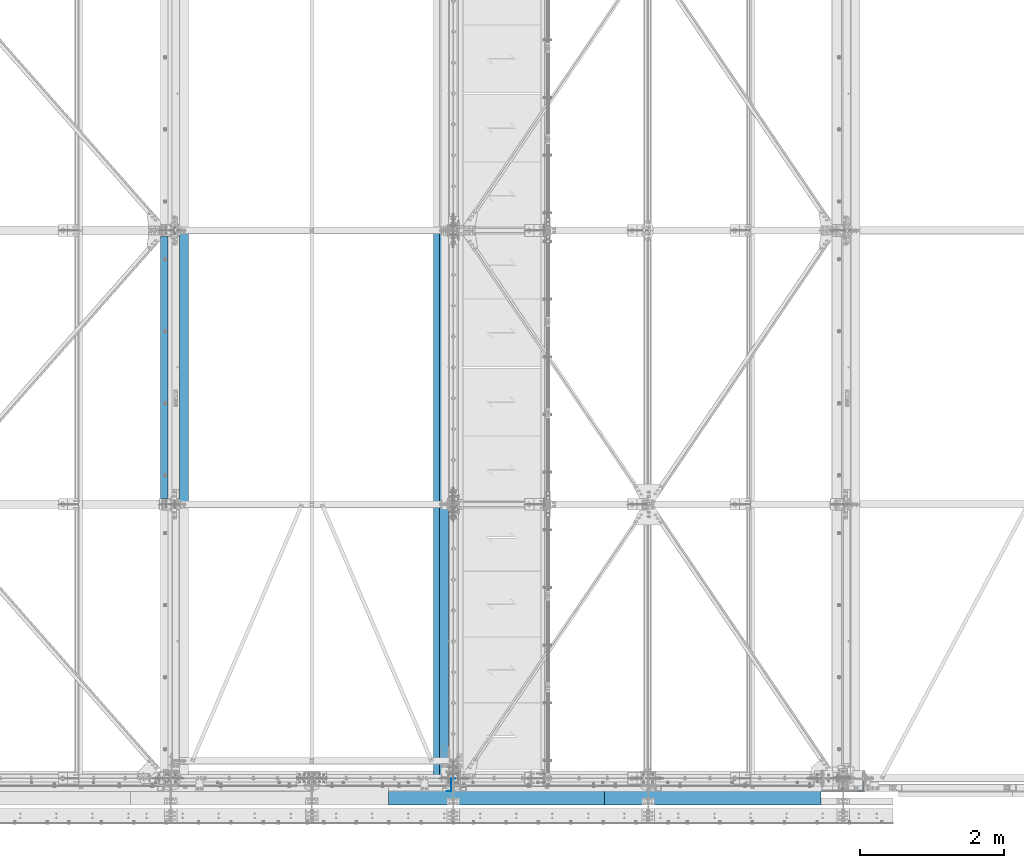
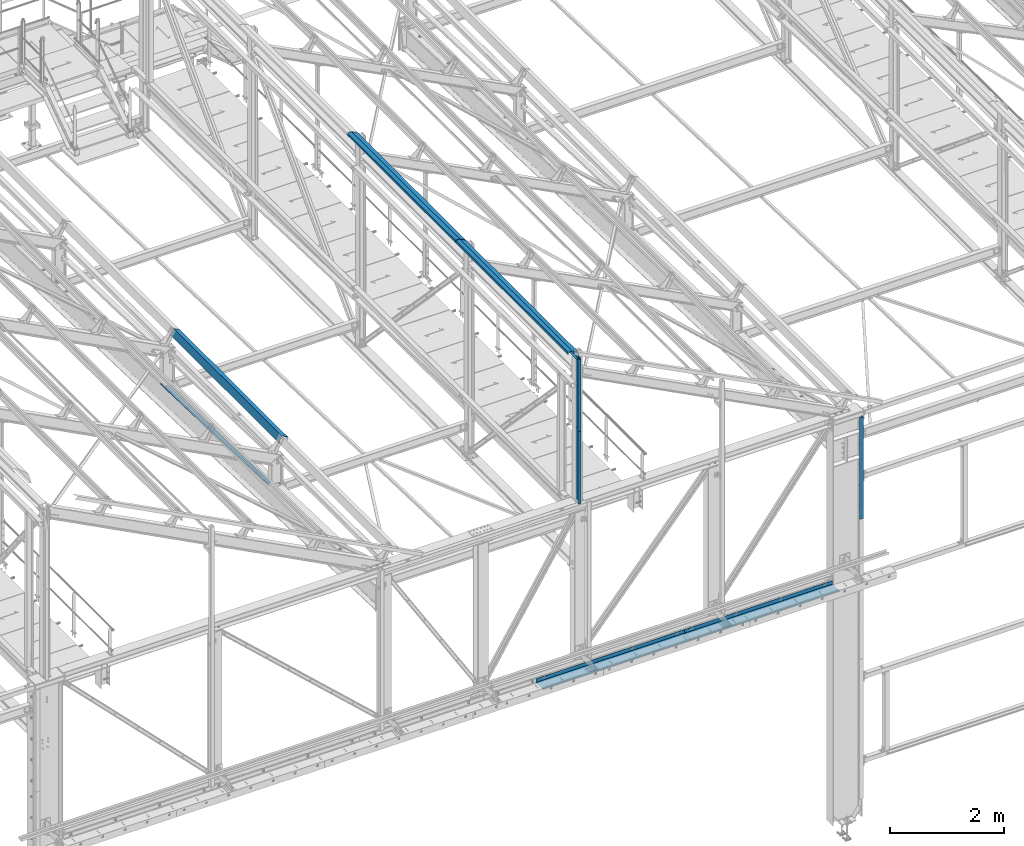
# One storey, part 347 of 496: 9 beams, 9 elements without a shape of their own.
"""IFC2X3 building model written with IfcOpenShell, lengths in millimetres."""

import ifcopenshell
import ifcopenshell.guid

model = None  # the IFC model being written
_history = None  # IfcOwnerHistory: only IFC2X3 demands one
_inside = {}  # id of a spatial element -> (the spatial element, [elements in it])
_under = {}  # id of a project, library or spatial element -> (it, [spatial elements below it])
_declared = {}  # id of a project -> (the project, [libraries it declares])
_typed = {}  # id of a type object -> (the type object, [elements of that type])
_made_of = {}  # id of a material, layer set ... -> (it, [elements and type objects made of it])


def new_model(schema):
    """Start an empty IFC model of exactly this schema.

    Asked for "IFC4X3", IfcOpenShell would pick the latest addendum, in which some entities
    have other attributes; the version numbers below select the first issue.
    IFC2X3 requires an IfcOwnerHistory on every rooted entity: one is made here for all.
    """
    global model, _history
    if schema == "IFC4X3":
        model = ifcopenshell.file(schema_version=(4, 3, 0, 0))
    else:
        model = ifcopenshell.file(schema=schema)
    _inside.clear()
    _under.clear()
    _declared.clear()
    _typed.clear()
    _made_of.clear()
    _history = None
    if model.schema == "IFC2X3":
        org = make("IfcOrganization", Name="unknown")
        user = make(
            "IfcPersonAndOrganization",
            ThePerson=make("IfcPerson", FamilyName="unknown"),
            TheOrganization=org,
        )
        app = make(
            "IfcApplication",
            ApplicationDeveloper=org,
            Version="unknown",
            ApplicationFullName="unknown",
            ApplicationIdentifier="unknown",
        )
        _history = make(
            "IfcOwnerHistory",
            OwningUser=user,
            OwningApplication=app,
            ChangeAction="ADDED",
            CreationDate=0,
        )
    return model


def make(cls, **values):
    """One entity of the class cls with the attributes given. An attribute that is None is left unset."""
    return model.create_entity(
        cls, **{name: value for name, value in values.items() if value is not None}
    )


def rooted(cls, **values):
    """An entity with a GlobalId (a new one), such as an element, a storey or a relation."""
    return make(cls, GlobalId=ifcopenshell.guid.new(), OwnerHistory=_history, **values)


def si_unit(unit_type, name, prefix=None):
    """IfcSIUnit, for example si_unit("LENGTHUNIT", "METRE", prefix="MILLI")."""
    return make("IfcSIUnit", UnitType=unit_type, Prefix=prefix, Name=name)


def assignment(units):
    """IfcUnitAssignment: the units of a project."""
    return None if units is None else make("IfcUnitAssignment", Units=units)


def point(xyz):
    """IfcCartesianPoint."""
    return None if xyz is None else make("IfcCartesianPoint", Coordinates=xyz)


def direction(xyz):
    """IfcDirection."""
    return None if xyz is None else make("IfcDirection", DirectionRatios=xyz)


def frame(location, z_axis=None, x_axis=None):
    """IfcAxis2Placement3D, a coordinate frame: its origin and axes. An axis left out is left unset."""
    return make(
        "IfcAxis2Placement3D",
        Location=point(location),
        Axis=direction(z_axis),
        RefDirection=direction(x_axis),
    )


def origin_with_axes():
    """The frame at (0, 0, 0) with the z axis (0, 0, 1) and the x axis (1, 0, 0) written out."""
    return frame((0.0, 0.0, 0.0), z_axis=(0.0, 0.0, 1.0), x_axis=(1.0, 0.0, 0.0))


def place(relative_to, where):
    """IfcLocalPlacement: puts the frame where relative to a parent placement (None: the world)."""
    return make(
        "IfcLocalPlacement", PlacementRelTo=relative_to, RelativePlacement=where
    )


def context(
    kind, dimensions, precision=None, world=None, true_north=None, identifier=None
):
    """IfcGeometricRepresentationContext, for example the 3D "Model" context."""
    return make(
        "IfcGeometricRepresentationContext",
        ContextIdentifier=identifier,
        ContextType=kind,
        CoordinateSpaceDimension=dimensions,
        Precision=precision,
        WorldCoordinateSystem=world,
        TrueNorth=true_north,
    )


def subcontext(parent, identifier, kind, view, scale=None):
    """IfcGeometricRepresentationSubContext, for example "Body" below "Model"."""
    return make(
        "IfcGeometricRepresentationSubContext",
        ContextIdentifier=identifier,
        ContextType=kind,
        ParentContext=parent,
        TargetScale=scale,
        TargetView=view,
    )


def project(units=None, contexts=None):
    """IfcProject with its units and contexts."""
    return rooted(
        "IfcProject",
        Name="project",
        RepresentationContexts=contexts,
        UnitsInContext=assignment(units),
    )


def spatial(cls, under=None, at=None, **own):
    """A site, building, storey or space (cls), placed at a placement, below another one or the project."""
    s = rooted(cls, ObjectPlacement=at, **own)
    if under is not None:
        _under.setdefault(under.id(), (under, []))[1].append(s)
    return s


def faces_of(points, faces, orient=None, outer=None):
    """IfcFace entities. A face is a list of loops; a loop is a list of indices into points, from 0.

    orient and outer hold one flag for each loop. By default every Orientation is true, the
    first loop of a face is its IfcFaceOuterBound and the others are IfcFaceBound.
    """
    made = []
    for i, loops in enumerate(faces):
        bounds = []
        for j, loop in enumerate(loops):
            is_outer = j == 0 if outer is None else outer[i][j]
            bounds.append(
                make(
                    "IfcFaceOuterBound" if is_outer else "IfcFaceBound",
                    Bound=make("IfcPolyLoop", Polygon=[points[k] for k in loop]),
                    Orientation=True if orient is None else orient[i][j],
                )
            )
        made.append(make("IfcFace", Bounds=bounds))
    return made


def faceted_brep(points, faces, orient=None, outer=None, voids=None):
    """IfcFacetedBrep: a solid bounded by flat faces; with voids (closed shells), ...WithVoids."""
    shared = [point(p) for p in points]
    hull = make("IfcClosedShell", CfsFaces=faces_of(shared, faces, orient, outer))
    if voids is None:
        return make("IfcFacetedBrep", Outer=hull)
    return make(
        "IfcFacetedBrepWithVoids",
        Outer=hull,
        Voids=[
            make(cls, CfsFaces=faces_of(shared, fs, o, b)) for cls, fs, o, b in voids
        ],
    )


def shape(context_of_items, identifier, shape_type, items):
    """IfcShapeRepresentation: the items that make up one representation, for example the "Body"."""
    return make(
        "IfcShapeRepresentation",
        ContextOfItems=context_of_items,
        RepresentationIdentifier=identifier,
        RepresentationType=shape_type,
        Items=items,
    )


def material(Name=None, Category=None):
    """IfcMaterial."""
    return make("IfcMaterial", Name=Name, Category=Category)


def made_of(thing, what):
    """Note that an element or type object is made of a material, layer set ...; save() writes the relation."""
    if what is not None:
        _made_of.setdefault(what.id(), (what, []))[1].append(thing)
    return thing


def type_object(cls, material=None, **own):
    """A type object (cls), such as IfcWallType, which elements share."""
    return made_of(rooted(cls, **own), material)


def element(
    cls,
    number,
    at=None,
    inside=None,
    cuts=None,
    type_object=None,
    material=None,
    context=None,
    identifier="Body",
    shape_type=None,
    held_by="IfcProductDefinitionShape",
    body=None,
    shapes=None,
    **own,
):
    """One element of the class cls, such as IfcWall. Its Tag is "e" and its number.

    at: its placement. inside: the storey or other place that contains it. cuts: it is an
    opening in that element (IfcRelVoidsElement). A single representation is given by context,
    identifier, shape_type and body (its items); several are given by shapes. held_by: the class
    of the entity that holds the representations. save() writes the other relations.
    """
    e = rooted(cls, Tag="e%d" % number, ObjectPlacement=at, **own)
    if body is not None:
        shapes = [shape(context, identifier, shape_type, body)]
    if shapes is not None:
        e.Representation = make(held_by, Representations=shapes)
    if inside is not None:
        _inside.setdefault(inside.id(), (inside, []))[1].append(e)
    if cuts is not None:
        rooted(
            "IfcRelVoidsElement", RelatingBuildingElement=cuts, RelatedOpeningElement=e
        )
    if type_object is not None:
        _typed.setdefault(type_object.id(), (type_object, []))[1].append(e)
    return made_of(e, material)


def aggregate(whole, parts):
    """IfcRelAggregates: a whole, such as a stair, and the parts it consists of."""
    return rooted("IfcRelAggregates", RelatingObject=whole, RelatedObjects=parts)


def save(model, path):
    """Write the relations noted so far, then the file.

    IfcRelAggregates (storeys below a building ...), IfcRelContainedInSpatialStructure (elements
    in a storey), IfcRelDefinesByType, IfcRelAssociatesMaterial and IfcRelDeclares: one each for
    every whole, place, type object, material and project.
    """
    for whole, parts in _under.values():
        aggregate(whole, parts)
    for where, things in _inside.values():
        rooted(
            "IfcRelContainedInSpatialStructure",
            RelatedElements=things,
            RelatingStructure=where,
        )
    for kind, things in _typed.values():
        rooted("IfcRelDefinesByType", RelatedObjects=things, RelatingType=kind)
    for what, things in _made_of.values():
        rooted("IfcRelAssociatesMaterial", RelatedObjects=things, RelatingMaterial=what)
    for by, libraries in _declared.values():
        rooted("IfcRelDeclares", RelatingContext=by, RelatedDefinitions=libraries)
    model.write(path)


model = new_model("IFC2X3")

# Units and contexts
model_context = context("Model", 3, precision=1e-05, world=origin_with_axes())
body_context = subcontext(model_context, "Body", "Model", "MODEL_VIEW")
ifc_project = project(units=[si_unit("LENGTHUNIT", "METRE", prefix="MILLI"), si_unit("AREAUNIT", "SQUARE_METRE"), si_unit("VOLUMEUNIT", "CUBIC_METRE"), si_unit("MASSUNIT", "GRAM", prefix="KILO"), si_unit("TIMEUNIT", "SECOND"), si_unit("PLANEANGLEUNIT", "RADIAN"), si_unit("SOLIDANGLEUNIT", "STERADIAN"), si_unit("THERMODYNAMICTEMPERATUREUNIT", "DEGREE_CELSIUS"), si_unit("LUMINOUSINTENSITYUNIT", "LUMEN")], contexts=[model_context])

# Site, building, storey
site_placement = place(None, origin_with_axes())
site = spatial("IfcSite", under=ifc_project, at=site_placement, CompositionType="ELEMENT")
building_placement = place(site_placement, origin_with_axes())
building = spatial("IfcBuilding", under=site, at=building_placement, Name="Undefined", CompositionType="ELEMENT")
storey_placement = place(building_placement, origin_with_axes())
storey = spatial("IfcBuildingStorey", under=building, at=storey_placement, Name="Undefined", CompositionType="ELEMENT", Elevation=0.0)

# Assembly, beam
assembly_1_placement = place(storey_placement, origin_with_axes())
assembly_1 = element("IfcElementAssembly", 1, at=assembly_1_placement, inside=storey, Name="SHED", AssemblyPlace="NOTDEFINED", PredefinedType="NOTDEFINED")
ifc_material = material(Name="Undefined/S235-E24")
beam_type_1 = type_object("IfcBeamType", PredefinedType="NOTDEFINED")
beam_1_placement = place(assembly_1_placement, frame((19656.0539262703, 5700.00010459345, 8773.41543701898), z_axis=(0.0, 1.0, 0.0), x_axis=(-0.886081824994261, -1.3000000762986e-08, 0.46352885499701)))
beam_1 = element("IfcBeam", 2, at=beam_1_placement, type_object=beam_type_1, material=ifc_material, Name="SHED", context=body_context, shape_type="Brep", body=[
    faceted_brep([(-3.49427864421159e-08, -1.49999999999636, -1895.0), (-3.52956703864038e-08, -1.5, 1895.0), (3.49573383573443e-08, 1.5, 1895.0), (3.53102223016322e-08, 1.5, -1895.0), (47.0000011861484, 1.499998899395, 1895.0), (47.0000011898519, 1.49999889939863, -1895.0), (50.0000011927114, -1.50000117085074, -1895.0), (50.0000011890152, -1.50000117085438, 1895.0), (47.000001059947, 135.500002207569, 1895.00000000012), (47.0000010603762, 135.500002214732, -1894.99999999988), (50.0000010575095, 138.500002217588, -1894.99999999987), (50.0000010570839, 138.500002210421, 1895.00000000013), (-88.1836776470482, 135.500002842484, 1895.0000000002), (-88.1836776506789, 135.500002845067, -1894.9999999998), (-90.0000023299144, 138.50000208251, -1894.99999999975), (-90.0000023251705, 138.500002079061, 1895.00000000025), (-124.424035514965, 66.2228546085316, 1895.00000000021), (-124.424035518201, 66.2228546098777, -1894.99999999979), (-127.082281608209, 67.6134399916555, 1895.00000000021), (-127.082281611441, 67.6134399930015, -1894.99999999979)], [[[0, 1, 2, 3]], [[3, 2, 4, 5]], [[1, 0, 6, 7]], [[5, 4, 8, 9]], [[7, 6, 10, 11]], [[9, 8, 12, 13]], [[11, 10, 14, 15]], [[13, 12, 16, 17]], [[12, 8, 4, 2, 1, 7, 11, 15, 18, 16]], [[15, 14, 19, 18]], [[14, 10, 6, 0, 3, 5, 9, 13, 17, 19]], [[18, 19, 17, 16]]]),
])
aggregate(assembly_1, [beam_1])

assembly_2_placement = place(storey_placement, origin_with_axes())
assembly_2 = element("IfcElementAssembly", 3, at=assembly_2_placement, inside=storey, Name="SHED", AssemblyPlace="NOTDEFINED", PredefinedType="NOTDEFINED")
beam_2_placement = place(assembly_2_placement, frame((23194.99999895, 5700.00015768597, 11825.822934218), z_axis=(0.0, 1.0, 0.0), x_axis=(0.0, 0.0, 1.0)))
beam_2 = element("IfcBeam", 4, at=beam_2_placement, type_object=beam_type_1, material=ifc_material, Name="SHED", context=body_context, shape_type="Brep", body=[
    faceted_brep([(-3.49427864421159e-08, -1.49999999999636, -1895.0), (-3.52956703864038e-08, -1.5, 1895.0), (3.49573383573443e-08, 1.5, 1895.0), (3.53102223016322e-08, 1.5, -1895.0), (47.0000011861484, 1.499998899395, 1895.0), (47.0000011898519, 1.49999889939863, -1895.0), (50.0000011927114, -1.50000117085074, -1895.0), (50.0000011890152, -1.50000117085438, 1895.0), (47.0, 83.4669820349482, 1895.0), (47.0, 83.4669820349482, -1895.0), (50.0, 84.198112487793, -1895.0), (50.0, 84.198112487793, 1895.0), (-16.2373286826551, 205.5, 1895.0), (-16.2373286826551, 205.5, -1895.0), (-14.4130535125732, 208.5, -1895.0), (-14.4130535125732, 208.5, 1895.0), (-151.413055419922, 205.5, 1895.0), (-151.413055419922, 205.5, -1895.0), (-154.413055419922, 208.5, -1895.0), (-154.413055419922, 208.5, 1895.0), (-151.413055419922, 158.5, 1895.0), (-151.413055419922, 158.5, -1895.0), (-154.413055419922, 158.5, 1895.0), (-154.413055419922, 158.5, -1895.0)], [[[0, 1, 2, 3]], [[3, 2, 4, 5]], [[1, 0, 6, 7]], [[5, 4, 8, 9]], [[7, 6, 10, 11]], [[9, 8, 12, 13]], [[11, 10, 14, 15]], [[13, 12, 16, 17]], [[15, 14, 18, 19]], [[17, 16, 20, 21]], [[16, 12, 8, 4, 2, 1, 7, 11, 15, 19, 22, 20]], [[19, 18, 23, 22]], [[18, 14, 10, 6, 0, 3, 5, 9, 13, 17, 21, 23]], [[22, 23, 21, 20]]]),
])
aggregate(assembly_2, [beam_2])

assembly_3_placement = place(storey_placement, origin_with_axes())
assembly_3 = element("IfcElementAssembly", 5, at=assembly_3_placement, inside=storey, Name="SUPPORT", AssemblyPlace="NOTDEFINED", PredefinedType="NOTDEFINED")
beam_type_2 = type_object("IfcBeamType", PredefinedType="NOTDEFINED")
beam_3_placement = place(assembly_3_placement, frame((27070.0, -111.5, 5080.00085614788), z_axis=(1.0, 0.0, 0.0), x_axis=(0.0, 0.0, -1.0)))
beam_3 = element("IfcBeam", 6, at=beam_3_placement, type_object=beam_type_2, material=ifc_material, Name="SUPPORT", context=body_context, shape_type="Brep", body=[
    faceted_brep([(0.0, -1.5, -1500.0), (0.0, -1.5, 1500.0), (0.0, 1.5, 1500.0), (0.0, 1.5, -1500.0), (80.0, 1.5, 1500.0), (80.0, 1.5, -1500.0), (77.0, -1.5, -1500.0), (77.0, -1.5, 1500.0), (80.0, -258.5, 1500.0), (80.0, -258.5, -1500.0), (77.0, -255.5, -1500.0), (77.0, -255.5, 1500.0), (30.0000019073486, -258.5, 1500.0), (30.0000019073486, -258.5, -1500.0), (30.0000019073486, -255.5, 1500.0), (30.0000019073486, -255.5, -1500.0)], [[[0, 1, 2, 3]], [[3, 2, 4, 5]], [[1, 0, 6, 7]], [[5, 4, 8, 9]], [[7, 6, 10, 11]], [[9, 8, 12, 13]], [[8, 4, 2, 1, 7, 11, 14, 12]], [[11, 10, 15, 14]], [[10, 6, 0, 3, 5, 9, 13, 15]], [[14, 15, 13, 12]]]),
])
aggregate(assembly_3, [beam_3])

assembly_4_placement = place(storey_placement, origin_with_axes())
assembly_4 = element("IfcElementAssembly", 7, at=assembly_4_placement, inside=storey, Name="SUPPORT", AssemblyPlace="NOTDEFINED", PredefinedType="NOTDEFINED")
beam_4_placement = place(assembly_4_placement, frame((24070.0, -111.5, 5080.00085614788), z_axis=(1.0, 0.0, 0.0), x_axis=(0.0, 0.0, -1.0)))
beam_4 = element("IfcBeam", 8, at=beam_4_placement, type_object=beam_type_2, material=ifc_material, Name="SUPPORT", context=body_context, shape_type="Brep", body=[
    faceted_brep([(0.0, -1.5, -1500.0), (0.0, -1.5, 1500.0), (0.0, 1.5, 1500.0), (0.0, 1.5, -1500.0), (80.0, 1.5, 1500.0), (80.0, 1.5, -1500.0), (77.0, -1.5, -1500.0), (77.0, -1.5, 1500.0), (80.0, -258.5, 1500.0), (80.0, -258.5, -1500.0), (77.0, -255.5, -1500.0), (77.0, -255.5, 1500.0), (30.0000019073486, -258.5, 1500.0), (30.0000019073486, -258.5, -1500.0), (30.0000019073486, -255.5, 1500.0), (30.0000019073486, -255.5, -1500.0)], [[[0, 1, 2, 3]], [[3, 2, 4, 5]], [[1, 0, 6, 7]], [[5, 4, 8, 9]], [[7, 6, 10, 11]], [[9, 8, 12, 13]], [[8, 4, 2, 1, 7, 11, 14, 12]], [[11, 10, 15, 14]], [[10, 6, 0, 3, 5, 9, 13, 15]], [[14, 15, 13, 12]]]),
])
aggregate(assembly_4, [beam_4])

assembly_5_placement = place(storey_placement, origin_with_axes())
assembly_5 = element("IfcElementAssembly", 9, at=assembly_5_placement, inside=storey, AssemblyPlace="NOTDEFINED", PredefinedType="NOTDEFINED")
beam_type_3 = type_object("IfcBeamType", PredefinedType="NOTDEFINED")
beam_5_placement = place(assembly_5_placement, frame((29080.9999667389, -177.499999406672, 7340.0000156157), z_axis=(0.0, 0.0, 1.0), x_axis=(1.0, 0.0, 0.0)))
beam_5 = element("IfcBeam", 10, at=beam_5_placement, type_object=beam_type_3, material=ifc_material, context=body_context, shape_type="Brep", body=[
    faceted_brep([(80.0000295613936, 127.499996117884, -310.003917570147), (75.0000295613936, 127.500000570986, -310.003917570147), (75.000029981391, 67.5000005879541, -310.003917570147), (80.000029981391, 67.5000006229541, -310.003917570147), (75.000029981391, 67.5000005879541, -240.003917570147), (80.000029981391, 67.5000006229541, -240.003917570147), (80.0000295613936, 127.500000622957, -240.003917570147), (75.0000295613936, 127.500000570986, -240.003917570147), (-1.04046193882823e-09, -2.50000000000003, -1090.0), (-1.04046193882823e-09, -2.50000000000003, 1090.0), (1.04409991763532e-09, 2.49999999999997, 1090.0), (1.04409991763532e-09, 2.49999999999997, -1090.0), (75.0000304363966, 2.49999996867305, 1090.0), (75.0000304363966, 2.49999996867305, -1090.0), (80.0000304713976, -2.5000000334154, -1090.0), (75.0000295613936, 127.500000570986, -1090.0), (80.0000295613936, 127.500000605986, -1090.0), (80.0000304713976, -2.5000000334154, 1090.0), (80.0000299813946, 67.4999999666719, 1090.0), (75.0000299813946, 67.4999999316719, 1090.0), (80.0000299813983, 67.4999999666719, 1009.99871063232), (75.0000299813983, 67.4999999316719, 1009.99871063232), (80.0000295613936, 127.49998852258, 1009.99871063232), (75.0000295613936, 127.500000570986, 1009.99871063232), (80.0000295613936, 127.499999966672, 739.999999999999), (75.0000295613936, 127.500000570986, 739.999999999999), (80.0000299813983, 67.4999999666719, 739.999999999999), (75.0000299814019, 67.4999999316719, 739.999999999999), (80.0000299813983, 67.4999999666719, 539.998718261718), (75.0000299814019, 67.4999999316719, 539.998718261718), (80.0000295613936, 127.499991226963, 539.998718261718), (75.0000295613936, 127.500000570986, 539.998718261718), (80.0000295613936, 127.499999966672, 199.999999999999), (75.0000295613936, 127.500000570986, 199.999999999999), (80.0000299813946, 67.4999999666719, 199.999999999999), (75.0000299813946, 67.4999999316719, 199.999999999999), (80.0000299813946, 67.4999999666719, 119.998718261718), (75.0000299813946, 67.4999999316719, 119.998718261718), (80.0000295613936, 127.499993643646, 119.998718261718), (75.0000295613936, 127.500000570986, 119.998718261718)], [[[0, 1, 2, 3]], [[3, 2, 4, 5]], [[6, 5, 4, 7]], [[8, 9, 10, 11]], [[11, 10, 12, 13]], [[14, 8, 11, 13, 15, 16]], [[9, 8, 14, 17]], [[12, 10, 9, 17, 18, 19]], [[18, 20, 21, 19]], [[22, 23, 21, 20]], [[23, 22, 24, 25]], [[24, 26, 27, 25]], [[28, 29, 27, 26]], [[30, 31, 29, 28]], [[31, 30, 32, 33]], [[32, 34, 35, 33]], [[36, 37, 35, 34]], [[38, 39, 37, 36]], [[39, 38, 6, 7]], [[2, 1, 15, 13, 12, 19, 21, 23, 25, 27, 29, 31, 33, 35, 37, 39, 7, 4]], [[16, 15, 1, 0]], [[38, 36, 34, 32, 30, 28, 26, 24, 22, 20, 18, 17, 14, 16, 0, 3, 5, 6]]]),
])
aggregate(assembly_5, [beam_5])

assembly_6_placement = place(storey_placement, origin_with_axes())
assembly_6 = element("IfcElementAssembly", 11, at=assembly_6_placement, inside=storey, Name="POUTRE", AssemblyPlace="NOTDEFINED", PredefinedType="NOTDEFINED")
beam_type_4 = type_object("IfcBeamType", PredefinedType="NOTDEFINED")
beam_6_placement = place(assembly_6_placement, frame((19509.9999999999, 5699.71696464352, 7871.88016099725), z_axis=(0.0, 0.999506556345274, -0.0314108870109058), x_axis=(-1.0, 0.0, 0.0)))
beam_6 = element("IfcBeam", 12, at=beam_6_placement, type_object=beam_type_4, material=ifc_material, Name="POUTRE", context=body_context, shape_type="Brep", body=[
    faceted_brep([(84.9999999979264, 0.999999999923602, 1895.93800542073), (84.9999999999563, 0.999999999923602, 1815.93800543636), (84.9999999999563, -1.00000000007185, 1815.93800543636), (84.9999999979264, -1.00000000007731, 1895.93800542073), (7.27595761418343e-12, 1.00000000000182, 1815.93800543633), (0.0, -0.999999999999091, 1815.93800543633), (97.9999999997781, 39.0000003423347, -1895.93800544557), (97.9999999997708, 0.999999999877218, -1895.93800544559), (97.9999999997854, 0.999999999877218, 1895.93800542178), (97.9999999997781, 39.0000003423356, 1895.9380054218), (99.9999999997781, 39.0000003423347, -1895.93800544557), (99.9999999997781, 39.0000003423356, 1895.9380054218), (99.9999999997708, -1.00000000012551, -1895.93800544559), (99.9999999997854, -1.0000000001246, 1895.93800542178), (85.0000000000728, -1.00000000007822, -1895.93800544091), (85.0000000000728, 0.999999999920874, -1895.9380054409), (85.0000000000582, -1.00000000007913, -1815.93800540536), (85.0000000000582, 0.999999999921783, -1815.93800540536), (0.0, 1.0, -1815.93800540536), (-7.27595761418343e-12, -1.00000000000091, -1815.93800540536)], [[[0, 1, 2, 3]], [[4, 5, 2, 1]], [[6, 7, 8, 9]], [[10, 6, 9, 11]], [[12, 10, 11, 13]], [[7, 6, 10, 12, 14, 15]], [[15, 14, 16, 17]], [[18, 17, 16, 19]], [[0, 8, 7, 15, 17, 18, 4, 1]], [[13, 11, 9, 8, 0, 3]], [[19, 16, 14, 12, 13, 3, 2, 5]], [[18, 19, 5, 4]]]),
])
aggregate(assembly_6, [beam_6])

assembly_7_placement = place(storey_placement, origin_with_axes())
assembly_7 = element("IfcElementAssembly", 13, at=assembly_7_placement, inside=storey, AssemblyPlace="NOTDEFINED", PredefinedType="NOTDEFINED")
beam_type_5 = type_object("IfcBeamType", PredefinedType="NOTDEFINED")
beam_7_placement = place(assembly_7_placement, frame((23500.0000002305, -4.25, 10895.0000000118), z_axis=(0.0, 0.0, 1.0), x_axis=(-1.0, 0.0, 0.0)))
beam_7 = element("IfcBeam", 14, at=beam_7_placement, type_object=beam_type_5, material=ifc_material, context=body_context, shape_type="Brep", body=[
    faceted_brep([(0.0, -1.5, -775.0), (0.0, -1.5, 775.0), (0.0, 1.5, 775.0), (0.0, 1.5, -775.0), (56.9999998985004, 1.5, 775.0), (56.9999998985004, 1.5, -775.0), (59.9999998985004, -1.5, -775.0), (59.9999998985004, -1.5, 775.0), (56.9999998985004, 175.75, 775.0), (56.9999998985004, 175.75, -775.0), (59.9999998985004, 172.75, -775.0), (59.9999998985004, 172.75, 775.0), (117.0, 175.75, 775.0), (117.0, 175.75, -775.0), (117.0, 172.75, 775.0), (117.0, 172.75, -775.0)], [[[0, 1, 2, 3]], [[3, 2, 4, 5]], [[1, 0, 6, 7]], [[5, 4, 8, 9]], [[7, 6, 10, 11]], [[9, 8, 12, 13]], [[8, 4, 2, 1, 7, 11, 14, 12]], [[11, 10, 15, 14]], [[10, 6, 0, 3, 5, 9, 13, 15]], [[14, 15, 13, 12]]]),
])
aggregate(assembly_7, [beam_7])

assembly_8_placement = place(storey_placement, origin_with_axes())
assembly_8 = element("IfcElementAssembly", 15, at=assembly_8_placement, inside=storey, AssemblyPlace="NOTDEFINED", PredefinedType="NOTDEFINED")
beam_8_placement = place(assembly_8_placement, frame((23500.0000002305, -4.25, 9345.0000000118), z_axis=(0.0, 0.0, 1.0), x_axis=(-1.0, 0.0, 0.0)))
beam_8 = element("IfcBeam", 16, at=beam_8_placement, type_object=beam_type_5, material=ifc_material, context=body_context, shape_type="Brep", body=[
    faceted_brep([(0.0, -1.5, -775.0), (0.0, -1.5, 775.0), (0.0, 1.5, 775.0), (0.0, 1.5, -775.0), (56.9999998985004, 1.5, 775.0), (56.9999998985004, 1.5, -775.0), (59.9999998985004, -1.5, -775.0), (59.9999998985004, -1.5, 775.0), (56.9999998985004, 175.75, 775.0), (56.9999998985004, 175.75, -775.0), (59.9999998985004, 172.75, -775.0), (59.9999998985004, 172.75, 775.0), (117.0, 175.75, 775.0), (117.0, 175.75, -775.0), (117.0, 172.75, 775.0), (117.0, 172.75, -775.0)], [[[0, 1, 2, 3]], [[3, 2, 4, 5]], [[1, 0, 6, 7]], [[5, 4, 8, 9]], [[7, 6, 10, 11]], [[9, 8, 12, 13]], [[8, 4, 2, 1, 7, 11, 14, 12]], [[11, 10, 15, 14]], [[10, 6, 0, 3, 5, 9, 13, 15]], [[14, 15, 13, 12]]]),
])
aggregate(assembly_8, [beam_8])

assembly_9_placement = place(storey_placement, origin_with_axes())
assembly_9 = element("IfcElementAssembly", 17, at=assembly_9_placement, inside=storey, Name="SHED", AssemblyPlace="NOTDEFINED", PredefinedType="NOTDEFINED")
beam_type_6 = type_object("IfcBeamType", PredefinedType="NOTDEFINED")
beam_9_placement = place(assembly_9_placement, frame((23194.99999895, 1820.00015768597, 11825.8229342211), z_axis=(0.0, -1.0, 0.0), x_axis=(0.0, 0.0, 1.0)))
beam_9 = element("IfcBeam", 18, at=beam_9_placement, type_object=beam_type_6, material=ifc_material, Name="SHED", context=body_context, shape_type="Brep", body=[
    faceted_brep([(-4.57293936051428e-09, -1.5, -1975.0), (-2.82670953311026e-09, -1.49999999999636, 1975.0), (4.57293936051428e-09, 1.50000000000364, 1975.0), (2.82307155430317e-09, 1.50000000000364, -1975.0), (50.0, 1.5, 1975.0), (50.0, 1.5, -1975.0), (47.0, -1.5, -1975.0), (47.0, -1.5, 1975.0), (50.0, -84.198112487793, 1975.0), (50.0, -84.198112487793, -1975.0), (47.0, -83.4669820349482, -1975.0), (47.0, -83.4669820349482, 1975.0), (-14.4130535125732, -208.5, 1975.0), (-14.4130535125732, -208.5, -1975.0), (-16.2373286826551, -205.5, -1975.0), (-16.2373286826551, -205.5, 1975.0), (-154.413055419922, -208.5, 1975.0), (-154.413055419922, -208.5, -1975.0), (-151.413055419922, -205.5, -1975.0), (-151.413055419922, -205.5, 1975.0), (-154.413055419922, -158.5, 1975.0), (-154.413055419922, -158.5, -1975.0), (-151.413055419922, -158.5, 1975.0), (-151.413055419922, -158.5, -1975.0)], [[[0, 1, 2, 3]], [[3, 2, 4, 5]], [[1, 0, 6, 7]], [[5, 4, 8, 9]], [[7, 6, 10, 11]], [[9, 8, 12, 13]], [[11, 10, 14, 15]], [[13, 12, 16, 17]], [[15, 14, 18, 19]], [[17, 16, 20, 21]], [[16, 12, 8, 4, 2, 1, 7, 11, 15, 19, 22, 20]], [[19, 18, 23, 22]], [[18, 14, 10, 6, 0, 3, 5, 9, 13, 17, 21, 23]], [[22, 23, 21, 20]]]),
])
aggregate(assembly_9, [beam_9])

save(model, "model.ifc")
